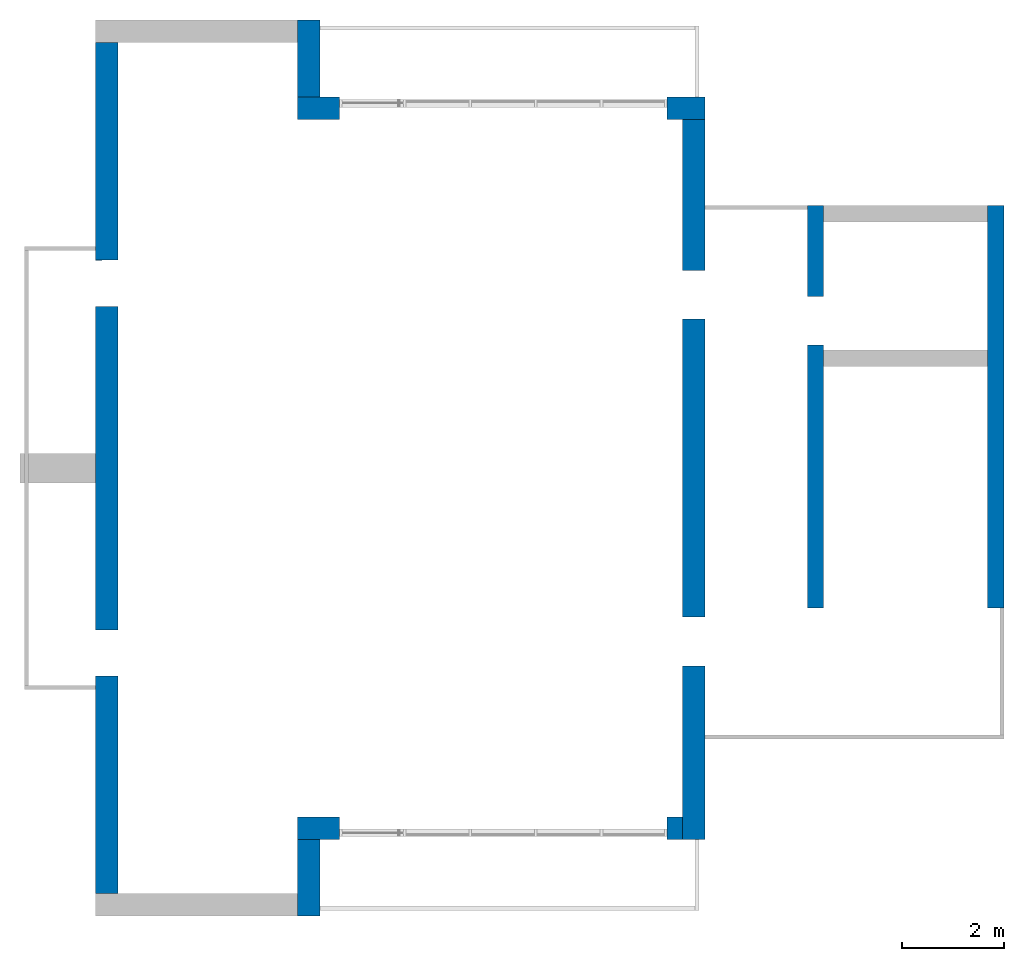
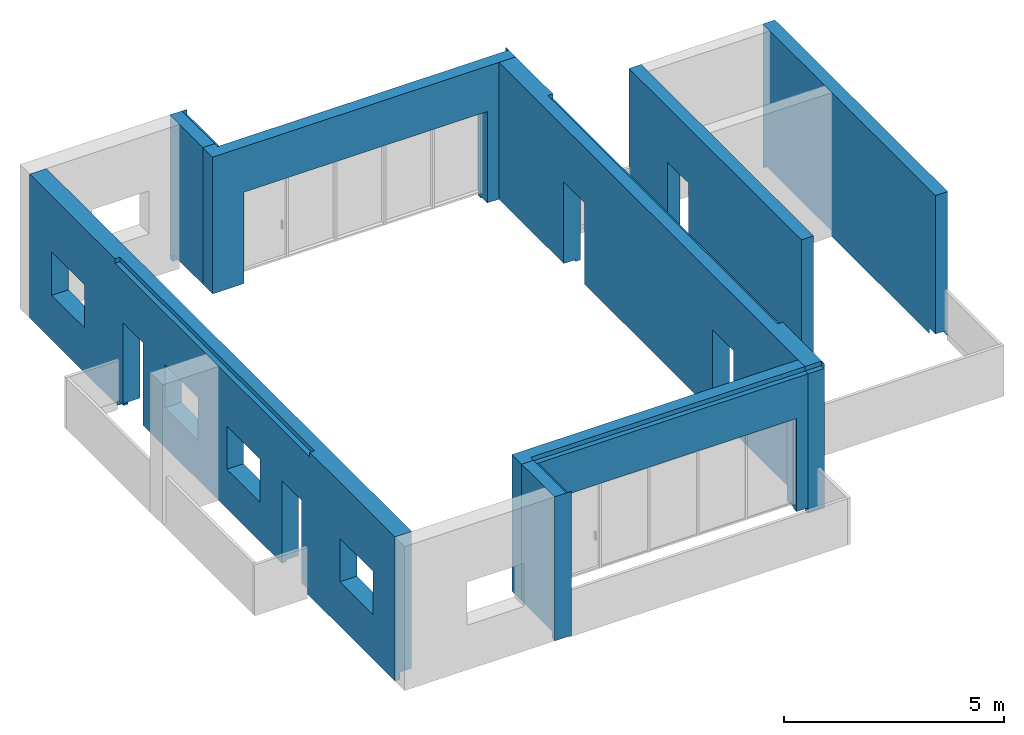
# One storey, part 3 of 4: 8 walls.
"""IFC2X3 building model written with IfcOpenShell, lengths in millimetres."""

import ifcopenshell
import ifcopenshell.guid

model = None  # the IFC model being written
_history = None  # IfcOwnerHistory: only IFC2X3 demands one
_inside = {}  # id of a spatial element -> (the spatial element, [elements in it])
_under = {}  # id of a project, library or spatial element -> (it, [spatial elements below it])
_declared = {}  # id of a project -> (the project, [libraries it declares])
_typed = {}  # id of a type object -> (the type object, [elements of that type])
_made_of = {}  # id of a material, layer set ... -> (it, [elements and type objects made of it])


def new_model(schema):
    """Start an empty IFC model of exactly this schema.

    Asked for "IFC4X3", IfcOpenShell would pick the latest addendum, in which some entities
    have other attributes; the version numbers below select the first issue.
    IFC2X3 requires an IfcOwnerHistory on every rooted entity: one is made here for all.
    """
    global model, _history
    if schema == "IFC4X3":
        model = ifcopenshell.file(schema_version=(4, 3, 0, 0))
    else:
        model = ifcopenshell.file(schema=schema)
    _inside.clear()
    _under.clear()
    _declared.clear()
    _typed.clear()
    _made_of.clear()
    _history = None
    if model.schema == "IFC2X3":
        org = make("IfcOrganization", Name="unknown")
        user = make(
            "IfcPersonAndOrganization",
            ThePerson=make("IfcPerson", FamilyName="unknown"),
            TheOrganization=org,
        )
        app = make(
            "IfcApplication",
            ApplicationDeveloper=org,
            Version="unknown",
            ApplicationFullName="unknown",
            ApplicationIdentifier="unknown",
        )
        _history = make(
            "IfcOwnerHistory",
            OwningUser=user,
            OwningApplication=app,
            ChangeAction="ADDED",
            CreationDate=0,
        )
    return model


def make(cls, **values):
    """One entity of the class cls with the attributes given. An attribute that is None is left unset."""
    return model.create_entity(
        cls, **{name: value for name, value in values.items() if value is not None}
    )


def entity(cls, *values):
    """Any entity or typed value of the class cls, its attributes in the order of the schema. None: left unset."""
    e = model.create_entity(cls)
    for i, value in enumerate(values):
        if value is not None:
            e[i] = value
    return e


def rooted(cls, **values):
    """An entity with a GlobalId (a new one), such as an element, a storey or a relation."""
    return make(cls, GlobalId=ifcopenshell.guid.new(), OwnerHistory=_history, **values)


def si_unit(unit_type, name, prefix=None):
    """IfcSIUnit, for example si_unit("LENGTHUNIT", "METRE", prefix="MILLI")."""
    return make("IfcSIUnit", UnitType=unit_type, Prefix=prefix, Name=name)


def converted_unit(unit_type, name, factor, base, dimensions=None, offset=None):
    """IfcConversionBasedUnit, such as the inch: factor (a typed value) times the base unit."""
    return make(
        "IfcConversionBasedUnit"
        if offset is None
        else "IfcConversionBasedUnitWithOffset",
        ConversionOffset=offset,
        Dimensions=None
        if dimensions is None
        else entity("IfcDimensionalExponents", *dimensions),
        UnitType=unit_type,
        Name=name,
        ConversionFactor=make(
            "IfcMeasureWithUnit", ValueComponent=factor, UnitComponent=base
        ),
    )


def derived_unit(unit_type, elements):
    """IfcDerivedUnit: a product of units, each with its exponent."""
    return make(
        "IfcDerivedUnit",
        Elements=[
            make("IfcDerivedUnitElement", Unit=unit, Exponent=power)
            for unit, power in elements
        ],
        UnitType=unit_type,
    )


def assignment(units):
    """IfcUnitAssignment: the units of a project."""
    return None if units is None else make("IfcUnitAssignment", Units=units)


def point(xyz):
    """IfcCartesianPoint."""
    return None if xyz is None else make("IfcCartesianPoint", Coordinates=xyz)


def direction(xyz):
    """IfcDirection."""
    return None if xyz is None else make("IfcDirection", DirectionRatios=xyz)


def frame(location, z_axis=None, x_axis=None):
    """IfcAxis2Placement3D, a coordinate frame: its origin and axes. An axis left out is left unset."""
    return make(
        "IfcAxis2Placement3D",
        Location=point(location),
        Axis=direction(z_axis),
        RefDirection=direction(x_axis),
    )


def origin():
    """The frame at (0, 0, 0) with its axes left unset."""
    return frame((0.0, 0.0, 0.0))


def place(relative_to, where):
    """IfcLocalPlacement: puts the frame where relative to a parent placement (None: the world)."""
    return make(
        "IfcLocalPlacement", PlacementRelTo=relative_to, RelativePlacement=where
    )


def context(
    kind, dimensions, precision=None, world=None, true_north=None, identifier=None
):
    """IfcGeometricRepresentationContext, for example the 3D "Model" context."""
    return make(
        "IfcGeometricRepresentationContext",
        ContextIdentifier=identifier,
        ContextType=kind,
        CoordinateSpaceDimension=dimensions,
        Precision=precision,
        WorldCoordinateSystem=world,
        TrueNorth=true_north,
    )


def subcontext(parent, identifier, kind, view, scale=None):
    """IfcGeometricRepresentationSubContext, for example "Body" below "Model"."""
    return make(
        "IfcGeometricRepresentationSubContext",
        ContextIdentifier=identifier,
        ContextType=kind,
        ParentContext=parent,
        TargetScale=scale,
        TargetView=view,
    )


def project(units=None, contexts=None):
    """IfcProject with its units and contexts."""
    return rooted(
        "IfcProject",
        Name="project",
        RepresentationContexts=contexts,
        UnitsInContext=assignment(units),
    )


def spatial(cls, under=None, at=None, **own):
    """A site, building, storey or space (cls), placed at a placement, below another one or the project."""
    s = rooted(cls, ObjectPlacement=at, **own)
    if under is not None:
        _under.setdefault(under.id(), (under, []))[1].append(s)
    return s


def faces_of(points, faces, orient=None, outer=None):
    """IfcFace entities. A face is a list of loops; a loop is a list of indices into points, from 0.

    orient and outer hold one flag for each loop. By default every Orientation is true, the
    first loop of a face is its IfcFaceOuterBound and the others are IfcFaceBound.
    """
    made = []
    for i, loops in enumerate(faces):
        bounds = []
        for j, loop in enumerate(loops):
            is_outer = j == 0 if outer is None else outer[i][j]
            bounds.append(
                make(
                    "IfcFaceOuterBound" if is_outer else "IfcFaceBound",
                    Bound=make("IfcPolyLoop", Polygon=[points[k] for k in loop]),
                    Orientation=True if orient is None else orient[i][j],
                )
            )
        made.append(make("IfcFace", Bounds=bounds))
    return made


def faceted_brep(points, faces, orient=None, outer=None, voids=None):
    """IfcFacetedBrep: a solid bounded by flat faces; with voids (closed shells), ...WithVoids."""
    shared = [point(p) for p in points]
    hull = make("IfcClosedShell", CfsFaces=faces_of(shared, faces, orient, outer))
    if voids is None:
        return make("IfcFacetedBrep", Outer=hull)
    return make(
        "IfcFacetedBrepWithVoids",
        Outer=hull,
        Voids=[
            make(cls, CfsFaces=faces_of(shared, fs, o, b)) for cls, fs, o, b in voids
        ],
    )


def shape(context_of_items, identifier, shape_type, items):
    """IfcShapeRepresentation: the items that make up one representation, for example the "Body"."""
    return make(
        "IfcShapeRepresentation",
        ContextOfItems=context_of_items,
        RepresentationIdentifier=identifier,
        RepresentationType=shape_type,
        Items=items,
    )


def material(Name=None, Category=None):
    """IfcMaterial."""
    return make("IfcMaterial", Name=Name, Category=Category)


def layer(
    of_material, thickness, ventilated=None, Name=None, Category=None, Priority=None
):
    """IfcMaterialLayer: one layer of a wall or slab, of a material (None: an air gap)."""
    return make(
        "IfcMaterialLayer",
        Material=of_material,
        LayerThickness=thickness,
        IsVentilated=ventilated,
        Name=Name,
        Category=Category,
        Priority=Priority,
    )


def layer_set(layers, Name=None):
    """IfcMaterialLayerSet."""
    return make("IfcMaterialLayerSet", MaterialLayers=layers, LayerSetName=Name)


def made_of(thing, what):
    """Note that an element or type object is made of a material, layer set ...; save() writes the relation."""
    if what is not None:
        _made_of.setdefault(what.id(), (what, []))[1].append(thing)
    return thing


def type_object(cls, material=None, **own):
    """A type object (cls), such as IfcWallType, which elements share."""
    return made_of(rooted(cls, **own), material)


def element(
    cls,
    number,
    at=None,
    inside=None,
    cuts=None,
    type_object=None,
    material=None,
    context=None,
    identifier="Body",
    shape_type=None,
    held_by="IfcProductDefinitionShape",
    body=None,
    shapes=None,
    **own,
):
    """One element of the class cls, such as IfcWall. Its Tag is "e" and its number.

    at: its placement. inside: the storey or other place that contains it. cuts: it is an
    opening in that element (IfcRelVoidsElement). A single representation is given by context,
    identifier, shape_type and body (its items); several are given by shapes. held_by: the class
    of the entity that holds the representations. save() writes the other relations.
    """
    e = rooted(cls, Tag="e%d" % number, ObjectPlacement=at, **own)
    if body is not None:
        shapes = [shape(context, identifier, shape_type, body)]
    if shapes is not None:
        e.Representation = make(held_by, Representations=shapes)
    if inside is not None:
        _inside.setdefault(inside.id(), (inside, []))[1].append(e)
    if cuts is not None:
        rooted(
            "IfcRelVoidsElement", RelatingBuildingElement=cuts, RelatedOpeningElement=e
        )
    if type_object is not None:
        _typed.setdefault(type_object.id(), (type_object, []))[1].append(e)
    return made_of(e, material)


def aggregate(whole, parts):
    """IfcRelAggregates: a whole, such as a stair, and the parts it consists of."""
    return rooted("IfcRelAggregates", RelatingObject=whole, RelatedObjects=parts)


def save(model, path):
    """Write the relations noted so far, then the file.

    IfcRelAggregates (storeys below a building ...), IfcRelContainedInSpatialStructure (elements
    in a storey), IfcRelDefinesByType, IfcRelAssociatesMaterial and IfcRelDeclares: one each for
    every whole, place, type object, material and project.
    """
    for whole, parts in _under.values():
        aggregate(whole, parts)
    for where, things in _inside.values():
        rooted(
            "IfcRelContainedInSpatialStructure",
            RelatedElements=things,
            RelatingStructure=where,
        )
    for kind, things in _typed.values():
        rooted("IfcRelDefinesByType", RelatedObjects=things, RelatingType=kind)
    for what, things in _made_of.values():
        rooted("IfcRelAssociatesMaterial", RelatedObjects=things, RelatingMaterial=what)
    for by, libraries in _declared.values():
        rooted("IfcRelDeclares", RelatingContext=by, RelatedDefinitions=libraries)
    model.write(path)


model = new_model("IFC2X3")

# Units and contexts
model_context = context("Model", 3, precision=0.01, world=origin(), true_north=direction((6.12303176911189e-17, 1.0)))
body_context = subcontext(model_context, "Body", "Model", "MODEL_VIEW")
ifc_project = project(units=[si_unit("LENGTHUNIT", "METRE", prefix="MILLI"), si_unit("AREAUNIT", "SQUARE_METRE"), si_unit("VOLUMEUNIT", "CUBIC_METRE"), converted_unit("PLANEANGLEUNIT", "DEGREE", entity("IfcRatioMeasure", 0.0174532925199433), si_unit("PLANEANGLEUNIT", "RADIAN"), dimensions=[0, 0, 0, 0, 0, 0, 0]), si_unit("MASSUNIT", "GRAM", prefix="KILO"), derived_unit("MASSDENSITYUNIT", [(si_unit("MASSUNIT", "GRAM", prefix="KILO"), 1), (si_unit("LENGTHUNIT", "METRE"), -3)]), si_unit("TIMEUNIT", "SECOND"), si_unit("FREQUENCYUNIT", "HERTZ"), si_unit("THERMODYNAMICTEMPERATUREUNIT", "DEGREE_CELSIUS"), derived_unit("THERMALTRANSMITTANCEUNIT", [(si_unit("MASSUNIT", "GRAM", prefix="KILO"), 1), (si_unit("THERMODYNAMICTEMPERATUREUNIT", "KELVIN"), -1), (si_unit("TIMEUNIT", "SECOND"), -3)]), derived_unit("VOLUMETRICFLOWRATEUNIT", [(si_unit("LENGTHUNIT", "METRE"), 3), (si_unit("TIMEUNIT", "SECOND"), -1)]), si_unit("ELECTRICCURRENTUNIT", "AMPERE"), si_unit("ELECTRICVOLTAGEUNIT", "VOLT"), si_unit("POWERUNIT", "WATT"), si_unit("FORCEUNIT", "NEWTON", prefix="KILO"), si_unit("ILLUMINANCEUNIT", "LUX"), si_unit("LUMINOUSFLUXUNIT", "LUMEN"), si_unit("LUMINOUSINTENSITYUNIT", "CANDELA"), derived_unit("USERDEFINED", [(si_unit("MASSUNIT", "GRAM", prefix="KILO"), -1), (si_unit("LENGTHUNIT", "METRE"), -2), (si_unit("TIMEUNIT", "SECOND"), 3), (si_unit("LUMINOUSFLUXUNIT", "LUMEN"), 1)]), derived_unit("LINEARVELOCITYUNIT", [(si_unit("LENGTHUNIT", "METRE"), 1), (si_unit("TIMEUNIT", "SECOND"), -1)]), si_unit("PRESSUREUNIT", "PASCAL"), derived_unit("USERDEFINED", [(si_unit("LENGTHUNIT", "METRE"), -2), (si_unit("MASSUNIT", "GRAM", prefix="KILO"), 1), (si_unit("TIMEUNIT", "SECOND"), -2)])], contexts=[model_context])

# Site, building, storey
site_placement = place(None, origin())
site = spatial("IfcSite", under=ifc_project, at=site_placement, CompositionType="ELEMENT")
building_placement = place(site_placement, origin())
building = spatial("IfcBuilding", under=site, at=building_placement, CompositionType="ELEMENT")
storey_placement = place(building_placement, frame((0.0, 0.0, 12000.0)))
storey = spatial("IfcBuildingStorey", under=building, at=storey_placement, Name="03 Level", CompositionType="ELEMENT", Elevation=12000.0)

# Walls
ifc_material_1 = material(Name="03")
ifc_layer_1 = layer(ifc_material_1, 10.0)
ifc_material_2 = material()
ifc_layer_2 = layer(ifc_material_2, 120.0)
ifc_material_3 = material()
ifc_layer_3 = layer(ifc_material_3, 300.0)
ifc_layer_4 = layer(ifc_material_1, 10.0)
ifc_layer_set_1 = layer_set([ifc_layer_1, ifc_layer_2, ifc_layer_3, ifc_layer_4], Name="Basic Wall:00_fal+12 cm")
wall_type_1 = type_object("IfcWallType", Name="Basic Wall:00_fal+12 cm", PredefinedType="STANDARD", material=ifc_layer_set_1)
wall_1_placement = place(storey_placement, frame((28723.4900708518, -62021.2395851401, -340.0), z_axis=(0.0, 0.0, 1.0), x_axis=(0.0, -1.0, 0.0)))
element("IfcWall", 1, at=wall_1_placement, inside=storey, type_object=wall_type_1, Name="Basic Wall:00_fal+12 cm", ObjectType="Basic Wall:00_fal+12 cm", context=body_context, shape_type="Brep", body=[
    faceted_brep([(9720.0, -220.0, 2465.0), (10670.0, -220.0, 2465.0), (10670.0, -220.0, 340.0), (10670.0, -220.0, 200.0), (13620.0, -220.0, 200.0), (13930.0, -220.0, 200.0), (13930.0, -220.0, 150.0), (13930.0, -220.0, 0.0), (14060.0, -220.0, 0.0), (14060.0, -220.0, 150.0), (14060.0, -220.0, 3875.0), (13930.0, -220.0, 3875.0), (13930.0, -220.0, 4000.0), (13620.0, -220.0, 4000.0), (9620.0, -220.0, 4000.0), (9470.0, -220.0, 4000.0), (6970.0, -220.0, 4000.0), (6650.0, -220.0, 4000.0), (4150.0, -220.0, 4000.0), (4000.0, -220.0, 4000.0), (0.0, -220.0, 4000.0), (0.0, -220.0, 3875.0), (0.0, -220.0, 200.0), (2950.0, -220.0, 200.0), (2950.0, -220.0, 340.0), (2950.0, -220.0, 2465.0), (3900.0, -220.0, 2465.0), (3900.0, -220.0, 340.0), (3900.0, -220.0, 200.0), (4000.0, -220.0, 200.0), (4150.0, -220.0, 200.0), (6650.0, -220.0, 200.0), (6970.0, -220.0, 200.0), (9470.0, -220.0, 200.0), (9620.0, -220.0, 200.0), (9720.0, -220.0, 200.0), (9720.0, -220.0, 340.0), (10670.0, 220.0, 2465.0), (9720.0, 220.0, 2465.0), (9720.0, 220.0, 340.0), (9720.0, 220.0, 150.0), (3900.0, 220.0, 150.0), (3900.0, 220.0, 340.0), (3900.0, 220.0, 2465.0), (2950.0, 220.0, 2465.0), (2950.0, 220.0, 340.0), (2950.0, 220.0, 150.0), (1764.5846054563, 220.0, 150.0), (1694.58460545631, 220.0, 150.0), (1694.58460545631, 220.0, 0.0), (0.0, 220.0, 0.0), (0.0, 220.0, 3875.0), (0.0, 220.0, 4000.0), (1694.58460545631, 220.0, 4000.0), (1694.58460545631, 220.0, 3875.0), (12149.5846054564, 220.0, 3875.0), (12149.5846054564, 220.0, 4000.0), (14060.0, 220.0, 4000.0), (14060.0, 220.0, 3875.0), (14060.0, 220.0, 0.0), (13620.0, 220.0, 0.0), (12094.5846054563, 220.0, 0.0), (12039.5846054563, 220.0, 0.0), (12039.5846054563, 220.0, 150.0), (12024.5846054563, 220.0, 150.0), (10670.0, 220.0, 150.0), (10670.0, 220.0, 340.0), (1694.58460545631, 90.0, 0.0), (0.0, 90.0, 0.0), (13930.0, 210.0, 4000.0), (14060.0, 210.0, 4000.0), (12149.5846054564, 90.0, 4000.0), (1694.58460545631, 90.0, 4000.0), (9720.0, -120.0, 200.0), (9720.0, 90.0, 200.0), (9720.0, 90.0, 150.0), (10670.0, 90.0, 150.0), (10670.0, 90.0, 200.0), (10670.0, -120.0, 200.0), (3900.0, 90.0, 150.0), (3900.0, 90.0, 200.0), (3900.0, -120.0, 200.0), (2950.0, -120.0, 200.0), (2950.0, 90.0, 200.0), (2950.0, 90.0, 150.0), (14060.0, 210.0, 3875.0), (0.0, 90.0, 200.0), (13930.0, 210.0, 3875.0), (12039.5846054563, 90.0, 150.0), (12039.5846054563, 90.0, 0.0), (1694.58460545631, 90.0, 150.0), (13930.0, 90.0, 200.0), (13930.0, 90.0, 0.0), (1694.58460545631, 90.0, 3875.0), (12149.5846054564, 90.0, 3875.0)], [[[0, 1, 2, 3, 4, 5, 6, 7, 8, 9, 10, 11, 12, 13, 14, 15, 16, 17, 18, 19, 20, 21, 22, 23, 24, 25, 26, 27, 28, 29, 30, 31, 32, 33, 34, 35, 36]], [[37, 38, 39, 40, 41, 42, 43, 44, 45, 46, 47, 48, 49, 50, 51, 52, 53, 54, 55, 56, 57, 58, 59, 60, 61, 62, 63, 64, 65, 66]], [[50, 49, 67, 68]], [[52, 20, 19, 18, 17, 16, 15, 14, 13, 12, 69, 70, 57, 56, 71, 72, 53]], [[38, 0, 36, 35, 73, 74, 75, 40, 39]], [[1, 0, 38, 37]], [[1, 37, 66, 65, 76, 77, 78, 3, 2]], [[26, 43, 42, 41, 79, 80, 81, 28, 27]], [[26, 25, 44, 43]], [[44, 25, 24, 23, 82, 83, 84, 46, 45]], [[8, 59, 58, 57, 70, 85, 10, 9]], [[21, 20, 52, 51]], [[51, 50, 68, 86, 22, 21]], [[85, 87, 11, 10]], [[87, 69, 12, 11]], [[69, 87, 85, 70]], [[63, 88, 76, 65, 64]], [[88, 63, 62, 89]], [[48, 90, 67, 49]], [[22, 86, 83, 82, 23]], [[68, 67, 90, 84, 83, 86]], [[91, 92, 7, 6, 5]], [[93, 94, 55, 54]], [[94, 71, 56, 55]], [[94, 93, 72, 71]], [[72, 93, 54, 53]], [[92, 91, 77, 76, 88, 89]], [[79, 75, 74, 80]], [[91, 5, 4, 3, 78, 77]], [[35, 34, 33, 32, 31, 30, 29, 28, 81, 80, 74, 73]], [[75, 79, 41, 40]], [[90, 48, 47, 46, 84]], [[59, 8, 7, 92, 89, 62, 61, 60]]]),
])
wall_2_placement = place(storey_placement, frame((28503.4900708518, -75861.2395851399, -190.0), z_axis=(0.0, 0.0, 1.0), x_axis=(-1.0, 0.0, 0.0)))
element("IfcWall", 2, at=wall_2_placement, inside=storey, type_object=wall_type_1, Name="Basic Wall:00_fal+12 cm", ObjectType="Basic Wall:00_fal+12 cm", context=body_context, shape_type="Brep", body=[
    faceted_brep([(7520.0, -220.0, 3850.0), (7200.0, -220.0, 3850.0), (0.0, -220.0, 3850.0), (0.0, -220.0, 190.0), (0.0, -220.0, 50.0), (300.0, -220.0, 50.0), (300.0, -220.0, 190.0), (300.0, -220.0, 2590.0), (6700.0, -220.0, 2590.0), (6700.0, -220.0, 190.0), (6700.0, -220.0, 50.0), (7200.0, -220.0, 50.0), (7520.0, -220.0, 50.0), (6700.0, 220.0, 2590.0), (300.0, 220.0, 2590.0), (300.0, 220.0, 190.0), (300.0, 220.0, 0.0), (0.0, 220.0, 0.0), (0.0, 220.0, 190.0), (0.0, 220.0, 3725.0), (7210.0, 220.0, 3725.0), (7210.0, 220.0, 3850.0), (7520.0, 220.0, 3850.0), (7520.0, 220.0, 50.0), (7210.0, 220.0, 50.0), (7210.0, 220.0, 0.0), (7080.0, 220.0, 0.0), (6700.0, 220.0, 0.0), (6700.0, 220.0, 190.0), (0.0, 90.0, 50.0), (300.0, 90.0, 50.0), (300.0, 15.0, 50.0), (7210.0, 90.0, 0.0), (7210.0, 90.0, 50.0), (6700.0, 90.0, 50.0), (6700.0, 90.0, 0.0), (300.0, 165.0, 0.0), (300.0, 90.0, 0.0), (0.0, 90.0, 0.0), (7210.0, 90.0, 3725.0), (0.0, 90.0, 3725.0), (7210.0, 90.0, 3850.0), (0.0, 90.0, 3850.0), (6700.0, 165.0, 0.0), (6700.0, 15.0, 50.0)], [[[0, 1, 2, 3, 4, 5, 6, 7, 8, 9, 10, 11, 12]], [[13, 14, 15, 16, 17, 18, 19, 20, 21, 22, 23, 24, 25, 26, 27, 28]], [[7, 14, 13, 8]], [[5, 4, 29, 30, 31]], [[32, 33, 34, 35]], [[24, 33, 32, 25]], [[0, 12, 23, 22]], [[17, 16, 36, 37, 38]], [[39, 20, 19, 40]], [[41, 39, 40, 42]], [[39, 41, 21, 20]], [[29, 4, 3, 2, 42, 40, 19, 18, 17, 38]], [[2, 1, 0, 22, 21, 41, 42]], [[14, 7, 6, 5, 31, 30, 37, 36, 16, 15]], [[8, 13, 28, 27, 43, 35, 34, 44, 10, 9]], [[32, 35, 43, 27, 26, 25]], [[29, 38, 37, 30]], [[33, 24, 23, 12, 11, 10, 44, 34]]]),
])
wall_3_placement = place(storey_placement, frame((21203.4900708518, -76081.2395851399, -340.0), z_axis=(0.0, 0.0, 1.0), x_axis=(0.0, -1.0, 0.0)))
element("IfcWall", 3, at=wall_3_placement, inside=storey, type_object=wall_type_1, Name="Basic Wall:00_fal+12 cm", ObjectType="Basic Wall:00_fal+12 cm", context=body_context, shape_type="Brep", body=[
    faceted_brep([(1500.0, -220.0, 4000.0), (1060.0, -220.0, 4000.0), (0.0, -220.0, 4000.0), (0.0, -220.0, 200.0), (1370.0, -220.0, 200.0), (1370.0, -220.0, 0.0), (1500.0, -220.0, 0.0), (1500.0, 220.0, 4000.0), (1500.0, 220.0, 3875.0), (1500.0, 220.0, 0.0), (1370.0, 220.0, 0.0), (1370.0, 220.0, 150.0), (1305.0, 220.0, 150.0), (0.0, 220.0, 150.0), (0.0, 220.0, 3875.0), (1490.0, 220.0, 3875.0), (1490.0, 220.0, 4000.0), (1370.0, 90.0, 0.0), (1490.0, 90.0, 4000.0), (0.0, 90.0, 4000.0), (0.0, 90.0, 3875.0), (0.0, 90.0, 150.0), (0.0, 90.0, 200.0), (1370.0, 90.0, 200.0), (1370.0, 90.0, 150.0), (1490.0, 90.0, 3875.0)], [[[0, 1, 2, 3, 4, 5, 6]], [[7, 8, 9, 10, 11, 12, 13, 14, 15, 16]], [[9, 6, 5, 17, 10]], [[2, 1, 0, 7, 16, 18, 19]], [[3, 2, 19, 20, 14, 13, 21, 22]], [[6, 9, 8, 7, 0]], [[22, 23, 4, 3]], [[23, 22, 21, 24]], [[4, 23, 24, 11, 10, 17, 5]], [[11, 24, 21, 13, 12]], [[20, 25, 15, 14]], [[25, 18, 16, 15]], [[18, 25, 20, 19]]]),
])
wall_4_placement = place(storey_placement, frame((17263.4900708518, -77141.2395851399, -340.0), z_axis=(0.0, 0.0, 1.0), x_axis=(0.0, 1.0, 0.0)))
element("IfcWall", 4, at=wall_4_placement, inside=storey, type_object=wall_type_1, Name="Basic Wall:00_fal+12 cm", ObjectType="Basic Wall:00_fal+12 cm", context=body_context, shape_type="Brep", body=[
    faceted_brep([(16620.0, -220.0, 4000.0), (12620.0, -220.0, 4000.0), (12470.0, -220.0, 4000.0), (8470.0, -220.0, 4000.0), (8150.0, -220.0, 4000.0), (4150.0, -220.0, 4000.0), (4000.0, -220.0, 4000.0), (0.0, -220.0, 4000.0), (0.0, -220.0, 200.0), (4000.0, -220.0, 200.0), (4150.0, -220.0, 200.0), (4250.0, -220.0, 200.0), (4250.0, -220.0, 2440.0), (5150.0, -220.0, 2440.0), (5150.0, -220.0, 200.0), (8150.0, -220.0, 200.0), (8470.0, -220.0, 200.0), (11470.0, -220.0, 200.0), (11470.0, -220.0, 2440.0), (12370.0, -220.0, 2440.0), (12370.0, -220.0, 200.0), (12470.0, -220.0, 200.0), (12620.0, -220.0, 200.0), (16620.0, -220.0, 200.0), (7650.0, -220.0, 2440.0), (7650.0, -220.0, 1240.0), (6150.0, -220.0, 1240.0), (6150.0, -220.0, 2440.0), (2500.0, -220.0, 2440.0), (2500.0, -220.0, 1240.0), (1000.0, -220.0, 1240.0), (1000.0, -220.0, 2440.0), (8970.0, -220.0, 1240.0), (8970.0, -220.0, 2440.0), (10470.0, -220.0, 2440.0), (10470.0, -220.0, 1240.0), (14120.0, -220.0, 1240.0), (14120.0, -220.0, 2440.0), (15620.0, -220.0, 2440.0), (15620.0, -220.0, 1240.0), (0.0, 220.0, 0.0), (0.0, 220.0, 4000.0), (3870.0, 220.0, 4000.0), (3880.0, 220.0, 4000.0), (3880.0, 220.0, 3875.0), (8020.0, 220.0, 3875.0), (8590.0, 220.0, 3875.0), (12740.0, 220.0, 3875.0), (12740.0, 220.0, 4000.0), (16490.0, 220.0, 4000.0), (16620.0, 220.0, 4000.0), (16620.0, 220.0, 0.0), (12620.0, 220.0, 0.0), (12620.0, 220.0, 150.0), (12555.0, 220.0, 150.0), (12360.0, 220.0, 150.0), (12360.0, 220.0, 200.0), (12370.0, 220.0, 200.0), (12370.0, 220.0, 340.0), (12370.0, 220.0, 2440.0), (11470.0, 220.0, 2440.0), (11470.0, 220.0, 340.0), (11460.0, 220.0, 340.0), (11460.0, 220.0, 150.0), (8590.0, 220.0, 150.0), (8020.0, 220.0, 150.0), (5150.0, 220.0, 150.0), (5150.0, 220.0, 340.0), (5150.0, 220.0, 2440.0), (4250.0, 220.0, 2440.0), (4250.0, 220.0, 340.0), (4250.0, 220.0, 150.0), (4065.0, 220.0, 150.0), (4000.0, 220.0, 150.0), (4000.0, 220.0, 0.0), (7650.0, 220.0, 1240.0), (7650.0, 220.0, 2440.0), (6150.0, 220.0, 2440.0), (6150.0, 220.0, 1240.0), (2500.0, 220.0, 1240.0), (2500.0, 220.0, 2440.0), (1000.0, 220.0, 2440.0), (1000.0, 220.0, 1240.0), (8970.0, 220.0, 2440.0), (8970.0, 220.0, 1240.0), (10470.0, 220.0, 1240.0), (10470.0, 220.0, 2440.0), (14120.0, 220.0, 2440.0), (14120.0, 220.0, 1240.0), (15620.0, 220.0, 1240.0), (15620.0, 220.0, 2440.0), (0.0, 90.0, 0.0), (4000.0, 90.0, 0.0), (12740.0, 90.0, 4000.0), (3880.0, 90.0, 4000.0), (0.0, 90.0, 200.0), (4250.0, -120.0, 200.0), (4250.0, 90.0, 200.0), (4250.0, 90.0, 150.0), (5150.0, 90.0, 150.0), (5150.0, 90.0, 200.0), (5150.0, -120.0, 200.0), (16620.0, 90.0, 200.0), (16620.0, 90.0, 0.0), (12370.0, 90.0, 200.0), (12360.0, 90.0, 200.0), (11470.0, -120.0, 200.0), (11470.0, -120.0, 340.0), (4000.0, 90.0, 150.0), (12620.0, 90.0, 150.0), (12620.0, 90.0, 0.0), (3880.0, 90.0, 3875.0), (12740.0, 90.0, 3875.0), (11460.0, -120.0, 340.0), (11460.0, -120.0, 200.0), (11460.0, 90.0, 200.0), (11460.0, 90.0, 150.0), (12360.0, 90.0, 150.0)], [[[0, 1, 2, 3, 4, 5, 6, 7, 8, 9, 10, 11, 12, 13, 14, 15, 16, 17, 18, 19, 20, 21, 22, 23], [24, 25, 26, 27], [28, 29, 30, 31], [32, 33, 34, 35], [36, 37, 38, 39]], [[40, 41, 42, 43, 44, 45, 46, 47, 48, 49, 50, 51, 52, 53, 54, 55, 56, 57, 58, 59, 60, 61, 62, 63, 64, 65, 66, 67, 68, 69, 70, 71, 72, 73, 74], [75, 76, 77, 78], [79, 80, 81, 82], [83, 84, 85, 86], [87, 88, 89, 90]], [[91, 40, 74, 92]], [[7, 6, 5, 4, 3, 2, 1, 0, 50, 49, 48, 93, 94, 43, 42, 41]], [[7, 41, 40, 91, 95, 8]], [[12, 11, 96, 97, 98, 71, 70, 69]], [[13, 12, 69, 68]], [[14, 13, 68, 67, 66, 99, 100, 101]], [[51, 50, 0, 23, 102, 103]], [[104, 57, 56, 105]], [[20, 19, 59, 58, 57, 104]], [[60, 59, 19, 18]], [[18, 17, 106, 107, 61, 60]], [[76, 75, 25, 24]], [[77, 76, 24, 27]], [[78, 77, 27, 26]], [[75, 78, 26, 25]], [[80, 79, 29, 28]], [[81, 80, 28, 31]], [[82, 81, 31, 30]], [[79, 82, 30, 29]], [[33, 32, 84, 83]], [[34, 33, 83, 86]], [[35, 34, 86, 85]], [[32, 35, 85, 84]], [[37, 36, 88, 87]], [[38, 37, 87, 90]], [[39, 38, 90, 89]], [[36, 39, 89, 88]], [[23, 22, 21, 20, 104, 102]], [[95, 91, 92, 108, 98, 97]], [[108, 73, 72, 71, 98]], [[109, 53, 52, 110]], [[73, 108, 92, 74]], [[111, 112, 47, 46, 45, 44]], [[112, 93, 48, 47]], [[112, 111, 94, 93]], [[94, 111, 44, 43]], [[113, 62, 61, 107]], [[62, 113, 114, 115, 116, 63]], [[113, 107, 106, 114]], [[56, 55, 117, 105]], [[53, 109, 117, 55, 54]], [[66, 65, 64, 63, 116, 99]], [[100, 99, 116, 115]], [[103, 102, 104, 105, 117, 109, 110]], [[17, 16, 15, 14, 101, 100, 115, 114, 106]], [[8, 95, 97, 96, 11, 10, 9]], [[51, 103, 110, 52]]]),
])
wall_5_placement = place(storey_placement, frame((21203.4900708518, -61581.23958514, -340.0), z_axis=(0.0, 0.0, 1.0), x_axis=(0.0, 1.0, 0.0)))
element("IfcWall", 5, at=wall_5_placement, inside=storey, type_object=wall_type_1, Name="Basic Wall:00_fal+12 cm", ObjectType="Basic Wall:00_fal+12 cm", context=body_context, shape_type="Brep", body=[
    faceted_brep([(1500.0, -220.0, 0.0), (1500.0, -220.0, 3875.0), (1500.0, -220.0, 4000.0), (1490.0, -220.0, 4000.0), (1490.0, -220.0, 3875.0), (0.0, -220.0, 3875.0), (0.0, -220.0, 150.0), (1305.0, -220.0, 150.0), (1370.0, -220.0, 150.0), (1370.0, -220.0, 0.0), (0.0, 220.0, 4000.0), (1060.0, 220.0, 4000.0), (1500.0, 220.0, 4000.0), (1500.0, 220.0, 0.0), (1370.0, 220.0, 0.0), (1370.0, 220.0, 200.0), (0.0, 220.0, 200.0), (1370.0, -90.0, 0.0), (0.0, -90.0, 4000.0), (1490.0, -90.0, 4000.0), (1490.0, -90.0, 3875.0), (0.0, -90.0, 3875.0), (0.0, -90.0, 200.0), (0.0, -90.0, 150.0), (1370.0, -90.0, 200.0), (1370.0, -90.0, 150.0)], [[[0, 1, 2, 3, 4, 5, 6, 7, 8, 9]], [[10, 11, 12, 13, 14, 15, 16]], [[13, 0, 9, 17, 14]], [[12, 11, 10, 18, 19, 3, 2]], [[0, 13, 12, 2, 1]], [[4, 20, 21, 5]], [[20, 19, 18, 21]], [[19, 20, 4, 3]], [[18, 10, 16, 22, 23, 6, 5, 21]], [[15, 24, 22, 16]], [[24, 15, 14, 17, 9, 8, 25]], [[22, 24, 25, 23]], [[25, 8, 7, 6, 23]]]),
])
wall_6_placement = place(storey_placement, frame((28943.4900708518, -61801.23958514, -340.0), z_axis=(0.0, 0.0, 1.0), x_axis=(-1.0, 0.0, 0.0)))
element("IfcWall", 6, at=wall_6_placement, inside=storey, type_object=wall_type_1, Name="Basic Wall:00_fal+12 cm", ObjectType="Basic Wall:00_fal+12 cm", context=body_context, shape_type="Brep", body=[
    faceted_brep([(740.0, -220.0, 2740.0), (7140.0, -220.0, 2740.0), (7140.0, -220.0, 340.0), (7140.0, -220.0, 150.0), (7520.0, -220.0, 150.0), (7650.0, -220.0, 150.0), (7650.0, -220.0, 200.0), (7960.0, -220.0, 200.0), (7960.0, -220.0, 4000.0), (7650.0, -220.0, 4000.0), (7650.0, -220.0, 3875.0), (7520.0, -220.0, 3875.0), (10.0, -220.0, 3875.0), (10.0, -220.0, 4000.0), (0.0, -220.0, 4000.0), (0.0, -220.0, 3875.0), (0.0, -220.0, 0.0), (130.0, -220.0, 0.0), (130.0, -220.0, 150.0), (195.0, -220.0, 150.0), (740.0, -220.0, 150.0), (740.0, -220.0, 340.0), (0.0, 220.0, 4000.0), (440.0, 220.0, 4000.0), (7640.0, 220.0, 4000.0), (7960.0, 220.0, 4000.0), (7960.0, 220.0, 200.0), (7640.0, 220.0, 200.0), (7140.0, 220.0, 200.0), (7140.0, 220.0, 340.0), (7140.0, 220.0, 2740.0), (740.0, 220.0, 2740.0), (740.0, 220.0, 340.0), (740.0, 220.0, 200.0), (440.0, 220.0, 200.0), (130.0, 220.0, 200.0), (130.0, 220.0, 0.0), (0.0, 220.0, 0.0), (0.0, 220.0, 3875.0), (130.0, -90.0, 200.0), (740.0, -15.0, 200.0), (740.0, -90.0, 200.0), (7650.0, -90.0, 200.0), (7650.0, -90.0, 150.0), (7140.0, -90.0, 150.0), (7140.0, -90.0, 200.0), (130.0, -90.0, 150.0), (130.0, -90.0, 0.0), (740.0, -90.0, 150.0), (740.0, -165.0, 150.0), (7650.0, -90.0, 3875.0), (10.0, -90.0, 3875.0), (7650.0, -90.0, 4000.0), (10.0, -90.0, 4000.0), (7140.0, -15.0, 200.0), (7140.0, -165.0, 150.0)], [[[0, 1, 2, 3, 4, 5, 6, 7, 8, 9, 10, 11, 12, 13, 14, 15, 16, 17, 18, 19, 20, 21]], [[22, 23, 24, 25, 26, 27, 28, 29, 30, 31, 32, 33, 34, 35, 36, 37, 38]], [[0, 31, 30, 1]], [[39, 35, 34, 33, 40, 41]], [[42, 6, 5, 43]], [[42, 43, 44, 45]], [[35, 39, 46, 18, 17, 47, 36]], [[18, 46, 48, 49, 20, 19]], [[50, 51, 12, 11, 10]], [[52, 50, 10, 9]], [[51, 53, 13, 12]], [[51, 50, 52, 53]], [[16, 15, 14, 22, 38, 37]], [[37, 36, 47, 17, 16]], [[25, 24, 23, 22, 14, 13, 53, 52, 9, 8]], [[31, 0, 21, 20, 49, 48, 41, 40, 33, 32]], [[1, 30, 29, 28, 54, 45, 44, 55, 3, 2]], [[25, 8, 7, 26]], [[43, 5, 4, 3, 55, 44]], [[46, 39, 41, 48]], [[6, 42, 45, 54, 28, 27, 26, 7]]]),
])
ifc_layer_5 = layer(ifc_material_1, 10.0)
ifc_layer_6 = layer(ifc_material_3, 300.0)
ifc_layer_7 = layer(ifc_material_1, 10.0)
ifc_layer_set_2 = layer_set([ifc_layer_5, ifc_layer_6, ifc_layer_7], Name="Basic Wall:00_fal 300 mm")
wall_type_2 = type_object("IfcWallType", Name="Basic Wall:00_fal 300 mm", PredefinedType="STANDARD", material=ifc_layer_set_2)
wall_7_placement = place(storey_placement, frame((31103.4900708518, -63705.8241905964, -340.0), z_axis=(0.0, 0.0, 1.0), x_axis=(0.0, -1.0, 0.0)))
element("IfcWall", 7, at=wall_7_placement, inside=storey, type_object=wall_type_2, Name="Basic Wall:00_fal 300 mm", ObjectType="Basic Wall:00_fal 300 mm", context=body_context, shape_type="Brep", body=[
    faceted_brep([(7855.0, -160.0, 4000.0), (0.0, -160.0, 4000.0), (0.0, -160.0, 1290.0), (0.0, -160.0, 0.0), (10.0, -160.0, 0.0), (10.0, -160.0, 150.0), (80.0, -160.0, 150.0), (1770.0, -160.0, 150.0), (1770.0, -160.0, 340.0), (1770.0, -160.0, 2465.0), (2720.0, -160.0, 2465.0), (2720.0, -160.0, 340.0), (2720.0, -160.0, 150.0), (7855.0, -160.0, 150.0), (7855.0, -160.0, 340.0), (0.0, 160.0, 4000.0), (320.0, 160.0, 4000.0), (2820.0, 160.0, 4000.0), (3140.0, 160.0, 4000.0), (7855.0, 160.0, 4000.0), (7855.0, 160.0, 340.0), (7855.0, 160.0, 150.0), (7855.0, 160.0, 0.0), (3140.0, 160.0, 0.0), (3130.0, 160.0, 0.0), (3130.0, 160.0, 150.0), (2820.0, 160.0, 150.0), (2720.0, 160.0, 150.0), (2720.0, 160.0, 340.0), (2720.0, 160.0, 2465.0), (1770.0, 160.0, 2465.0), (1770.0, 160.0, 340.0), (1770.0, 160.0, 150.0), (320.0, 160.0, 150.0), (10.0, 160.0, 150.0), (10.0, 160.0, 0.0), (0.0, 160.0, 0.0), (7855.0, 150.0, 150.0), (7855.0, 150.0, 0.0), (2720.0, 60.0, 150.0), (1770.0, 60.0, 150.0), (3130.0, 150.0, 150.0), (3130.0, 150.0, 0.0)], [[[0, 1, 2, 3, 4, 5, 6, 7, 8, 9, 10, 11, 12, 13, 14]], [[15, 16, 17, 18, 19, 20, 21, 22, 23, 24, 25, 26, 27, 28, 29, 30, 31, 32, 33, 34, 35, 36]], [[4, 3, 36, 35]], [[19, 0, 14, 13, 37, 38, 22, 21, 20]], [[1, 0, 19, 18, 17, 16, 15]], [[10, 29, 28, 27, 39, 12, 11]], [[29, 10, 9, 30]], [[30, 9, 8, 7, 40, 32, 31]], [[41, 37, 13, 12, 39, 27, 26, 25]], [[34, 5, 4, 35]], [[42, 41, 25, 24]], [[37, 41, 42, 38]], [[36, 3, 2, 1, 15]], [[5, 34, 33, 32, 40, 7, 6]], [[24, 23, 22, 38, 42]]]),
])
wall_8_placement = place(storey_placement, frame((34623.4900708518, -63705.8241905964, -340.0), z_axis=(0.0, 0.0, 1.0), x_axis=(0.0, -1.0, 0.0)))
element("IfcWall", 8, at=wall_8_placement, inside=storey, type_object=wall_type_2, Name="Basic Wall:00_fal 300 mm", ObjectType="Basic Wall:00_fal 300 mm", context=body_context, shape_type="Brep", body=[
    faceted_brep([(7855.0, -160.0, 4000.0), (7575.0, -160.0, 4000.0), (3140.0, -160.0, 4000.0), (2820.0, -160.0, 4000.0), (320.0, -160.0, 4000.0), (0.0, -160.0, 4000.0), (0.0, -160.0, 0.0), (10.0, -160.0, 0.0), (10.0, -160.0, 150.0), (15.0, -160.0, 150.0), (320.0, -160.0, 150.0), (2820.0, -160.0, 150.0), (3130.0, -160.0, 150.0), (3130.0, -160.0, 0.0), (3140.0, -160.0, 0.0), (7575.0, -160.0, 0.0), (7575.0, -160.0, 150.0), (7855.0, -160.0, 150.0), (7855.0, 160.0, 0.0), (0.0, 160.0, 0.0), (0.0, 160.0, 4000.0), (570.0, 160.0, 4000.0), (2820.0, 160.0, 4000.0), (3140.0, 160.0, 4000.0), (7855.0, 160.0, 4000.0), (7855.0, 160.0, 1290.0), (3130.0, -150.0, 0.0), (7575.0, -150.0, 0.0), (7855.0, 80.0, 150.0), (7855.0, 150.0, 150.0), (7855.0, 150.0, 0.0), (7575.0, -150.0, 150.0), (3130.0, -150.0, 150.0), (10.0, 150.0, 150.0), (10.0, 150.0, 0.0)], [[[0, 1, 2, 3, 4, 5, 6, 7, 8, 9, 10, 11, 12, 13, 14, 15, 16, 17]], [[18, 19, 20, 21, 22, 23, 24, 25]], [[15, 14, 13, 26, 27]], [[18, 25, 24, 0, 17, 28, 29, 30]], [[5, 4, 3, 2, 1, 0, 24, 23, 22, 21, 20]], [[6, 5, 20, 19]], [[31, 32, 12, 11, 10, 9, 8, 33, 29, 28, 17, 16]], [[33, 34, 30, 29]], [[34, 33, 8, 7]], [[32, 31, 27, 26]], [[32, 26, 13, 12]], [[27, 31, 16, 15]], [[19, 18, 30, 34, 7, 6]]]),
])

save(model, "model.ifc")
